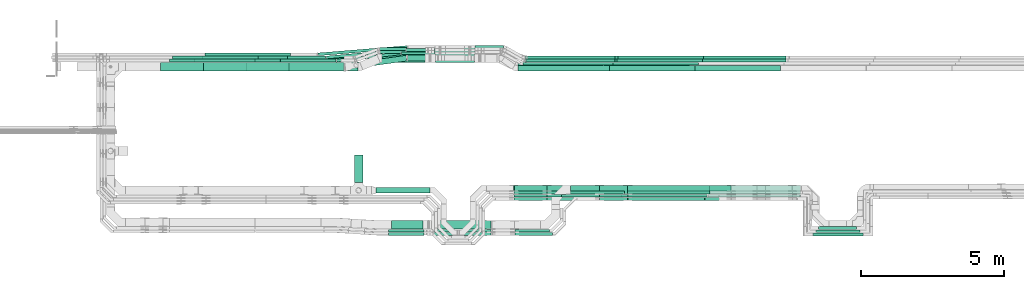
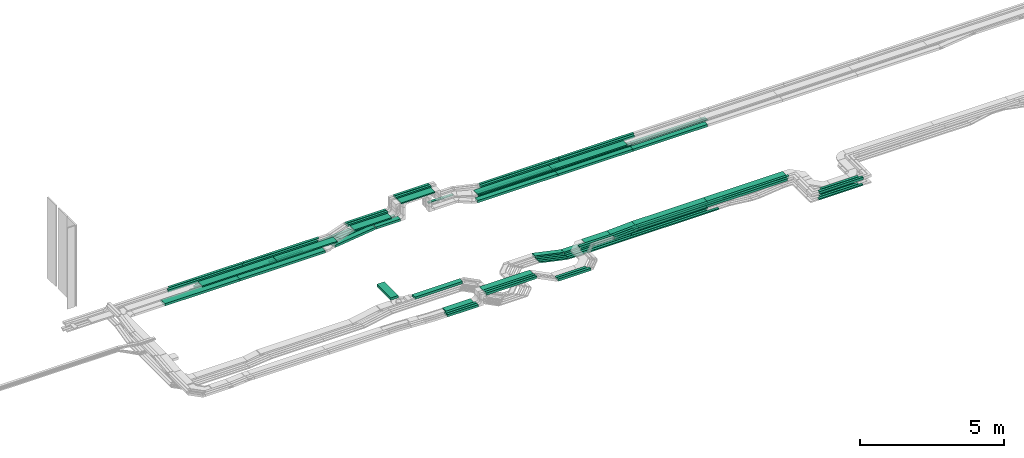
# One storey, part 2 of 32: 81 flow segments.
"""IFC2X3 building model written with IfcOpenShell, lengths in millimetres."""

from ifc_helpers import new_model, entity, si_unit, converted_unit, derived_unit, direction, frame, origin, origin_2d_with_axis, place, context, subcontext, project, spatial, rectangle, extrude, type_object, element, save


model = new_model("IFC2X3")

# Units and contexts
model_context = context("Model", 3, precision=0.01, world=origin(), true_north=direction((6.12303176911189e-17, 1.0)))
body_context = subcontext(model_context, "Body", "Model", "MODEL_VIEW")
ifc_project = project(units=[si_unit("LENGTHUNIT", "METRE", prefix="MILLI"), si_unit("AREAUNIT", "SQUARE_METRE"), si_unit("VOLUMEUNIT", "CUBIC_METRE"), converted_unit("PLANEANGLEUNIT", "DEGREE", entity("IfcRatioMeasure", 0.0174532925199433), si_unit("PLANEANGLEUNIT", "RADIAN"), dimensions=[0, 0, 0, 0, 0, 0, 0]), si_unit("MASSUNIT", "GRAM", prefix="KILO"), derived_unit("MASSDENSITYUNIT", [(si_unit("MASSUNIT", "GRAM", prefix="KILO"), 1), (si_unit("LENGTHUNIT", "METRE"), -3)]), derived_unit("MOMENTOFINERTIAUNIT", [(si_unit("LENGTHUNIT", "METRE"), 4)]), si_unit("TIMEUNIT", "SECOND"), si_unit("FREQUENCYUNIT", "HERTZ"), si_unit("THERMODYNAMICTEMPERATUREUNIT", "DEGREE_CELSIUS"), derived_unit("THERMALTRANSMITTANCEUNIT", [(si_unit("MASSUNIT", "GRAM", prefix="KILO"), 1), (si_unit("THERMODYNAMICTEMPERATUREUNIT", "KELVIN"), -1), (si_unit("TIMEUNIT", "SECOND"), -3)]), derived_unit("VOLUMETRICFLOWRATEUNIT", [(si_unit("LENGTHUNIT", "METRE"), 3), (si_unit("TIMEUNIT", "SECOND"), -1)]), derived_unit("MASSFLOWRATEUNIT", [(si_unit("MASSUNIT", "GRAM", prefix="KILO"), 1), (si_unit("TIMEUNIT", "SECOND"), -1)]), derived_unit("ROTATIONALFREQUENCYUNIT", [(si_unit("TIMEUNIT", "SECOND"), -1)]), si_unit("ELECTRICCURRENTUNIT", "AMPERE"), si_unit("ELECTRICVOLTAGEUNIT", "VOLT"), si_unit("POWERUNIT", "WATT"), si_unit("FORCEUNIT", "NEWTON", prefix="KILO"), si_unit("ILLUMINANCEUNIT", "LUX"), si_unit("LUMINOUSFLUXUNIT", "LUMEN"), si_unit("LUMINOUSINTENSITYUNIT", "CANDELA"), derived_unit("USERDEFINED", [(si_unit("MASSUNIT", "GRAM", prefix="KILO"), -1), (si_unit("LENGTHUNIT", "METRE"), -2), (si_unit("TIMEUNIT", "SECOND"), 3), (si_unit("LUMINOUSFLUXUNIT", "LUMEN"), 1)]), derived_unit("LINEARVELOCITYUNIT", [(si_unit("LENGTHUNIT", "METRE"), 1), (si_unit("TIMEUNIT", "SECOND"), -1)]), si_unit("PRESSUREUNIT", "PASCAL"), derived_unit("USERDEFINED", [(si_unit("LENGTHUNIT", "METRE"), -2), (si_unit("MASSUNIT", "GRAM", prefix="KILO"), 1), (si_unit("TIMEUNIT", "SECOND"), -2)]), derived_unit("LINEARFORCEUNIT", [(si_unit("MASSUNIT", "GRAM", prefix="KILO"), 1), (si_unit("LENGTHUNIT", "METRE"), 1), (si_unit("TIMEUNIT", "SECOND"), -2), (si_unit("LENGTHUNIT", "METRE"), -1)]), derived_unit("PLANARFORCEUNIT", [(si_unit("MASSUNIT", "GRAM", prefix="KILO"), 1), (si_unit("LENGTHUNIT", "METRE"), 1), (si_unit("TIMEUNIT", "SECOND"), -2), (si_unit("LENGTHUNIT", "METRE"), -2)])], contexts=[model_context])

# Site, building, storey
site_placement = place(None, origin())
site = spatial("IfcSite", under=ifc_project, at=site_placement, CompositionType="ELEMENT")
building_placement = place(site_placement, origin())
building = spatial("IfcBuilding", under=site, at=building_placement, CompositionType="ELEMENT")
storey_placement = place(building_placement, frame((0.0, 0.0, 8100.0)))
storey = spatial("IfcBuildingStorey", under=building, at=storey_placement, CompositionType="ELEMENT", Elevation=8100.0)

# Flow segments
cable_carrier_segment_type = type_object("IfcCableCarrierSegmentType", PredefinedType="CABLETRAYSEGMENT")
flow_segment_1_placement = place(storey_placement, frame((26941.01, 10275.0, 2800.0)))
element("IfcFlowSegment", 1, at=flow_segment_1_placement, inside=storey, type_object=cable_carrier_segment_type, context=body_context, shape_type="SweptSolid", body=[
    extrude(rectangle(XDim=962.025403932725, YDim=300.000000000001, at=origin_2d_with_axis()), frame((150.0, 481.01, 0.0), z_axis=(0.0, 0.0, 1.0), x_axis=(0.0, 1.0, 0.0)), (0.0, 0.0, 1.0), 99.9999999999968),
])
flow_segment_2_placement = place(storey_placement, frame((23148.44, 14174.5, 2565.0)))
element("IfcFlowSegment", 2, at=flow_segment_2_placement, inside=storey, type_object=cable_carrier_segment_type, context=body_context, shape_type="SweptSolid", body=[
    extrude(rectangle(XDim=3423.65642864429, YDim=300.000000000001, at=origin_2d_with_axis()), frame((1711.83, 150.0, 0.0), z_axis=(0.0, 0.0, 1.0), x_axis=(-1.0, 0.0, 0.0)), (0.0, 0.0, 1.0), 99.9999999999989),
])
flow_segment_3_placement = place(storey_placement, frame((28591.69, 14750.06, 2565.34)))
element("IfcFlowSegment", 3, at=flow_segment_3_placement, inside=storey, type_object=cable_carrier_segment_type, context=body_context, shape_type="SweptSolid", body=[
    extrude(rectangle(XDim=1171.51047122399, YDim=99.9999999999989, at=origin_2d_with_axis()), frame((585.76, 50.0, 0.0), z_axis=(0.0, 0.0, 1.0), x_axis=(-1.0, 0.0, 0.0)), (0.0, 0.0, 1.0), 50.0000000000016),
])
flow_segment_4_placement = place(storey_placement, frame((28756.97, 14860.06, 2570.0)))
element("IfcFlowSegment", 4, at=flow_segment_4_placement, inside=storey, type_object=cable_carrier_segment_type, context=body_context, shape_type="SweptSolid", body=[
    extrude(rectangle(XDim=1006.22734263624, YDim=99.9999999999989, at=origin_2d_with_axis()), frame((503.11, 50.0, 0.0), z_axis=(0.0, 0.0, 1.0), x_axis=(-1.0, 0.0, 0.0)), (0.0, 0.0, 1.0), 50.0000000000016),
])
flow_segment_5_placement = place(storey_placement, frame((27693.01, 9895.0, 2800.0)))
element("IfcFlowSegment", 5, at=flow_segment_5_placement, inside=storey, type_object=cable_carrier_segment_type, context=body_context, shape_type="SweptSolid", body=[
    extrude(rectangle(XDim=1902.46225527867, YDim=199.999999999998, at=origin_2d_with_axis()), frame((951.23, 100.0, 0.0)), (0.0, 0.0, 1.0), 100.000000000001),
])
flow_segment_6_placement = place(storey_placement, frame((39344.26, 9755.0, 2800.01)))
element("IfcFlowSegment", 6, at=flow_segment_6_placement, inside=storey, type_object=cable_carrier_segment_type, context=body_context, shape_type="SweptSolid", body=[
    extrude(rectangle(XDim=3242.93310217294, YDim=99.9999999999989, at=origin_2d_with_axis()), frame((1621.47, 50.0, 0.0), z_axis=(0.0, 0.0, 1.0), x_axis=(-1.0, 0.0, 0.0)), (0.0, 0.0, 1.0), 100.000000000001),
])
flow_segment_7_placement = place(storey_placement, frame((39398.1, 9875.0, 2800.02)))
element("IfcFlowSegment", 7, at=flow_segment_7_placement, inside=storey, type_object=cable_carrier_segment_type, context=body_context, shape_type="SweptSolid", body=[
    extrude(rectangle(XDim=3173.08952314652, YDim=300.000000000001, at=origin_2d_with_axis()), frame((1586.54, 150.0, 0.0), z_axis=(0.0, 0.0, 1.0), x_axis=(-1.0, 0.0, 0.0)), (0.0, 0.0, 1.0), 50.0000000000016),
])
flow_segment_8_placement = place(storey_placement, frame((31166.41, 14970.06, 2548.87)))
element("IfcFlowSegment", 8, at=flow_segment_8_placement, inside=storey, type_object=cable_carrier_segment_type, context=body_context, shape_type="SweptSolid", body=[
    extrude(rectangle(XDim=998.256803593107, YDim=99.9999999999989, at=origin_2d_with_axis()), frame((499.13, 50.0, 0.0)), (0.0, 0.0, 1.0), 50.0000000000016),
])
flow_segment_9_placement = place(storey_placement, frame((29758.2, 14900.06, 3325.0)))
element("IfcFlowSegment", 9, at=flow_segment_9_placement, inside=storey, type_object=cable_carrier_segment_type, context=body_context, shape_type="SweptSolid", body=[
    extrude(rectangle(XDim=1413.21398337131, YDim=99.9999999999989, at=origin_2d_with_axis()), frame((706.61, 50.0, 0.0)), (0.0, 0.0, 1.0), 99.9999999999989),
])
flow_segment_10_placement = place(storey_placement, frame((29758.2, 14790.06, 3325.0)))
element("IfcFlowSegment", 10, at=flow_segment_10_placement, inside=storey, type_object=cable_carrier_segment_type, context=body_context, shape_type="SweptSolid", body=[
    extrude(rectangle(XDim=1413.2139833713, YDim=99.9999999999989, at=origin_2d_with_axis()), frame((706.61, 50.0, 0.0)), (0.0, 0.0, 1.0), 99.9999999999989),
])
flow_segment_11_placement = place(storey_placement, frame((29783.2, 14480.06, 3325.0)))
element("IfcFlowSegment", 11, at=flow_segment_11_placement, inside=storey, type_object=cable_carrier_segment_type, context=body_context, shape_type="SweptSolid", body=[
    extrude(rectangle(XDim=1363.2139833713, YDim=300.000000000001, at=origin_2d_with_axis()), frame((681.61, 150.0, 0.0)), (0.0, 0.0, 1.0), 50.0000000000016),
])
flow_segment_12_placement = place(storey_placement, frame((43147.19, 8512.69, 2800.01)))
element("IfcFlowSegment", 12, at=flow_segment_12_placement, inside=storey, type_object=cable_carrier_segment_type, context=body_context, shape_type="SweptSolid", body=[
    extrude(rectangle(XDim=1512.20104272159, YDim=100.000000000001, at=origin_2d_with_axis()), frame((756.1, 50.0, 0.0)), (0.0, 0.0, 1.0), 99.9999999999989),
])
flow_segment_13_placement = place(storey_placement, frame((43027.19, 8402.69, 2799.28)))
element("IfcFlowSegment", 13, at=flow_segment_13_placement, inside=storey, type_object=cable_carrier_segment_type, context=body_context, shape_type="SweptSolid", body=[
    extrude(rectangle(XDim=1757.70736084199, YDim=100.000000000001, at=origin_2d_with_axis()), frame((878.85, 50.0, 0.0)), (0.0, 0.0, 1.0), 99.9999999999989),
])
flow_segment_14_placement = place(storey_placement, frame((43217.19, 8622.69, 2544.93)))
element("IfcFlowSegment", 14, at=flow_segment_14_placement, inside=storey, type_object=cable_carrier_segment_type, context=body_context, shape_type="SweptSolid", body=[
    extrude(rectangle(XDim=1332.2010427216, YDim=99.9999999999989, at=origin_2d_with_axis()), frame((666.1, 50.0, 0.0)), (0.0, 0.0, 1.0), 50.0000000000016),
])
flow_segment_15_placement = place(storey_placement, frame((43107.19, 8512.69, 2546.32)))
element("IfcFlowSegment", 15, at=flow_segment_15_placement, inside=storey, type_object=cable_carrier_segment_type, context=body_context, shape_type="SweptSolid", body=[
    extrude(rectangle(XDim=1552.2010427216, YDim=99.9999999999989, at=origin_2d_with_axis()), frame((776.1, 50.0, 0.0)), (0.0, 0.0, 1.0), 50.0000000000016),
])
flow_segment_16_placement = place(storey_placement, frame((42997.19, 8402.69, 2546.67)))
element("IfcFlowSegment", 16, at=flow_segment_16_placement, inside=storey, type_object=cable_carrier_segment_type, context=body_context, shape_type="SweptSolid", body=[
    extrude(rectangle(XDim=1772.70736117974, YDim=100.000000000001, at=origin_2d_with_axis()), frame((886.35, 50.0, 0.0)), (0.0, 0.0, 1.0), 50.0000000000016),
])
flow_segment_17_placement = place(storey_placement, frame((32683.5, 14182.28, 2854.5)))
element("IfcFlowSegment", 17, at=flow_segment_17_placement, inside=storey, type_object=cable_carrier_segment_type, context=body_context, shape_type="SweptSolid", body=[
    extrude(rectangle(XDim=2998.73000000508, YDim=300.000000000001, at=origin_2d_with_axis()), frame((1499.37, 150.0, 0.0)), (0.0, 0.0, 1.0), 50.0000000000016),
])
flow_segment_18_placement = place(storey_placement, frame((32966.27, 14492.28, 2855.0)))
element("IfcFlowSegment", 18, at=flow_segment_18_placement, inside=storey, type_object=cable_carrier_segment_type, context=body_context, shape_type="SweptSolid", body=[
    extrude(rectangle(XDim=3170.75891996771, YDim=99.9999999999989, at=origin_2d_with_axis()), frame((1585.38, 50.0, 0.0)), (0.0, 0.0, 1.0), 99.9999999999989),
])
flow_segment_19_placement = place(storey_placement, frame((33011.91, 14602.28, 2855.0)))
element("IfcFlowSegment", 19, at=flow_segment_19_placement, inside=storey, type_object=cable_carrier_segment_type, context=body_context, shape_type="SweptSolid", body=[
    extrude(rectangle(XDim=3172.25095291534, YDim=99.9999999999989, at=origin_2d_with_axis()), frame((1586.13, 50.0, 0.0)), (0.0, 0.0, 1.0), 99.9999999999989),
])
flow_segment_20_placement = place(storey_placement, frame((27909.76, 14480.06, 2840.02)))
element("IfcFlowSegment", 20, at=flow_segment_20_placement, inside=storey, type_object=cable_carrier_segment_type, context=body_context, shape_type="SweptSolid", body=[
    extrude(rectangle(XDim=1503.44239818237, YDim=300.000000000001, at=origin_2d_with_axis()), frame((751.72, 150.0, 0.0), z_axis=(0.0, 0.0, 1.0), x_axis=(-1.0, 0.0, 0.0)), (0.0, 0.0, 1.0), 50.0000000000016),
])
flow_segment_21_placement = place(storey_placement, frame((27841.26, 14790.06, 2840.0)))
element("IfcFlowSegment", 21, at=flow_segment_21_placement, inside=storey, type_object=cable_carrier_segment_type, context=body_context, shape_type="SweptSolid", body=[
    extrude(rectangle(XDim=1596.94010719343, YDim=99.9999999999989, at=origin_2d_with_axis()), frame((798.47, 50.0, 0.0), z_axis=(0.0, 0.0, 1.0), x_axis=(-1.0, 0.0, 0.0)), (0.0, 0.0, 1.0), 99.9999999999989),
])
flow_segment_22_placement = place(storey_placement, frame((27825.51, 14900.06, 2840.0)))
element("IfcFlowSegment", 22, at=flow_segment_22_placement, inside=storey, type_object=cable_carrier_segment_type, context=body_context, shape_type="SweptSolid", body=[
    extrude(rectangle(XDim=1612.69321013494, YDim=99.9999999999989, at=origin_2d_with_axis()), frame((806.35, 50.0, 0.0), z_axis=(0.0, 0.0, 1.0), x_axis=(-1.0, 0.0, 0.0)), (0.0, 0.0, 1.0), 99.9999999999989),
])
flow_segment_23_placement = place(storey_placement, frame((32920.1, 14602.28, 2548.87)))
element("IfcFlowSegment", 23, at=flow_segment_23_placement, inside=storey, type_object=cable_carrier_segment_type, context=body_context, shape_type="SweptSolid", body=[
    extrude(rectangle(XDim=3151.80224385144, YDim=99.9999999999989, at=origin_2d_with_axis()), frame((1575.9, 50.0, 0.0)), (0.0, 0.0, 1.0), 50.0000000000016),
])
for number, where in (
    (24, (32914.63, 14492.28, 2548.35)),
    (25, (32852.18, 14382.28, 2548.88)),
):
    element("IfcFlowSegment", number, at=place(storey_placement, frame(where)), inside=storey, type_object=cable_carrier_segment_type, context=body_context, shape_type="SweptSolid", body=[
        extrude(rectangle(XDim=3151.80224385145, YDim=99.9999999999989, at=origin_2d_with_axis()), frame((1575.9, 50.0, 0.0)), (0.0, 0.0, 1.0), 50.0000000000016),
    ])
flow_segment_24_placement = place(storey_placement, frame((28805.18, 14532.28, 2565.0)))
element("IfcFlowSegment", 26, at=flow_segment_24_placement, inside=storey, type_object=cable_carrier_segment_type, context=body_context, shape_type="SweptSolid", body=[
    extrude(rectangle(XDim=983.02375307789, YDim=199.999999999998, at=origin_2d_with_axis()), frame((491.51, 100.0, 0.0), z_axis=(0.0, 0.0, 1.0), x_axis=(-1.0, 0.0, 0.0)), (0.0, 0.0, 1.0), 99.9999999999989),
])
flow_segment_25_placement = place(storey_placement, frame((26317.41, 14493.99, 2565.34)))
element("IfcFlowSegment", 27, at=flow_segment_25_placement, inside=storey, type_object=cable_carrier_segment_type, context=body_context, shape_type="SweptSolid", body=[
    extrude(rectangle(XDim=2258.501959598, YDim=99.9999999999987, at=origin_2d_with_axis()), frame((1127.68, 177.18, 0.0), z_axis=(0.0, 0.0, 1.0), x_axis=(-0.993605819509294, -0.112904718401246, 0.0)), (0.0, 0.0, 1.0), 50.0000000000016),
])
flow_segment_26_placement = place(storey_placement, frame((25948.97, 14603.42, 2570.0)))
element("IfcFlowSegment", 28, at=flow_segment_26_placement, inside=storey, type_object=cable_carrier_segment_type, context=body_context, shape_type="SweptSolid", body=[
    extrude(rectangle(XDim=2794.85823056188, YDim=100.000000000001, at=origin_2d_with_axis()), frame((1396.14, 177.75, 0.0), z_axis=(0.0, 0.0, 1.0), x_axis=(-0.995798961229457, -0.0915665267132783, 0.0)), (0.0, 0.0, 1.0), 50.0000000000016),
])
flow_segment_27_placement = place(storey_placement, frame((25661.84, 14713.2, 2570.0)))
element("IfcFlowSegment", 29, at=flow_segment_27_placement, inside=storey, type_object=cable_carrier_segment_type, context=body_context, shape_type="SweptSolid", body=[
    extrude(rectangle(XDim=3133.42412206089, YDim=100.000000000001, at=origin_2d_with_axis()), frame((1565.55, 177.97, 0.0), z_axis=(0.0, 0.0, 1.0), x_axis=(-0.996649779456723, -0.0817876342050842, 0.0)), (0.0, 0.0, 1.0), 50.0000000000016),
])
flow_segment_28_placement = place(storey_placement, frame((26998.0, 14284.12, 2565.0)))
element("IfcFlowSegment", 30, at=flow_segment_28_placement, inside=storey, type_object=cable_carrier_segment_type, context=body_context, shape_type="SweptSolid", body=[
    extrude(rectangle(XDim=1773.75184296437, YDim=200.000000000002, at=origin_2d_with_axis()), frame((892.17, 222.31, 0.0), z_axis=(-7.09771272186529e-08, -9.962867704376e-09, 1.0), x_axis=(0.990291738549351, 0.139004577481819, 7.16729469263524e-08)), (0.0, 0.0, 1.0), 99.9999999999991),
])
flow_segment_29_placement = place(storey_placement, frame((29699.46, 8532.45, 3165.02)))
element("IfcFlowSegment", 31, at=flow_segment_29_placement, inside=storey, type_object=cable_carrier_segment_type, context=body_context, shape_type="SweptSolid", body=[
    extrude(rectangle(XDim=2026.05061924203, YDim=99.9999999999989, at=origin_2d_with_axis()), frame((1013.03, 50.0, 0.0)), (0.0, 0.0, 1.0), 99.9999999999989),
])
flow_segment_30_placement = place(storey_placement, frame((29699.46, 8422.45, 3164.3)))
element("IfcFlowSegment", 32, at=flow_segment_30_placement, inside=storey, type_object=cable_carrier_segment_type, context=body_context, shape_type="SweptSolid", body=[
    extrude(rectangle(XDim=2026.05032171429, YDim=99.9999999999989, at=origin_2d_with_axis()), frame((1013.03, 50.0, 0.0)), (0.0, 0.0, 1.0), 99.9999999999989),
])
flow_segment_31_placement = place(storey_placement, frame((29724.46, 8642.05, 3165.02)))
element("IfcFlowSegment", 33, at=flow_segment_31_placement, inside=storey, type_object=cable_carrier_segment_type, context=body_context, shape_type="SweptSolid", body=[
    extrude(rectangle(XDim=2007.04579485695, YDim=300.000000000001, at=origin_2d_with_axis()), frame((1003.52, 150.0, 0.0)), (0.0, 0.0, 1.0), 50.0000000000016),
])
flow_segment_32_placement = place(storey_placement, frame((32672.45, 14174.5, 2548.88)))
element("IfcFlowSegment", 34, at=flow_segment_32_placement, inside=storey, type_object=cable_carrier_segment_type, context=body_context, shape_type="SweptSolid", body=[
    extrude(rectangle(XDim=3209.55577942012, YDim=200.000000000002, at=origin_2d_with_axis()), frame((1604.78, 100.0, 0.0)), (0.0, 0.0, 1.0), 99.9999999999989),
])
flow_segment_33_placement = place(storey_placement, frame((39224.26, 9645.0, 2799.28)))
element("IfcFlowSegment", 35, at=flow_segment_33_placement, inside=storey, type_object=cable_carrier_segment_type, context=body_context, shape_type="SweptSolid", body=[
    extrude(rectangle(XDim=3242.93310217294, YDim=100.000000000001, at=origin_2d_with_axis()), frame((1621.47, 50.0, 0.0), z_axis=(0.0, 0.0, 1.0), x_axis=(-1.0, 0.0, 0.0)), (0.0, 0.0, 1.0), 99.9999999999989),
])
flow_segment_34_placement = place(storey_placement, frame((21649.82, 14182.28, 2840.02)))
element("IfcFlowSegment", 36, at=flow_segment_34_placement, inside=storey, type_object=cable_carrier_segment_type, context=body_context, shape_type="SweptSolid", body=[
    extrude(rectangle(XDim=2997.46000001016, YDim=300.000000000001, at=origin_2d_with_axis()), frame((1498.73, 150.0, 0.0)), (0.0, 0.0, 1.0), 50.0000000000016),
])
flow_segment_35_placement = place(storey_placement, frame((24649.82, 14182.28, 2840.02)))
element("IfcFlowSegment", 37, at=flow_segment_35_placement, inside=storey, type_object=cable_carrier_segment_type, context=body_context, shape_type="SweptSolid", body=[
    extrude(rectangle(XDim=2417.52833008933, YDim=300.000000000001, at=origin_2d_with_axis()), frame((1208.76, 150.0, 0.0)), (0.0, 0.0, 1.0), 50.0000000000016),
])
flow_segment_36_placement = place(storey_placement, frame((36074.45, 14602.28, 2548.87)))
element("IfcFlowSegment", 38, at=flow_segment_36_placement, inside=storey, type_object=cable_carrier_segment_type, context=body_context, shape_type="SweptSolid", body=[
    extrude(rectangle(XDim=2997.46000001016, YDim=99.9999999999989, at=origin_2d_with_axis()), frame((1498.73, 50.0, 0.0)), (0.0, 0.0, 1.0), 50.0000000000016),
])
flow_segment_37_placement = place(storey_placement, frame((39074.45, 14602.28, 2548.87)))
element("IfcFlowSegment", 39, at=flow_segment_37_placement, inside=storey, type_object=cable_carrier_segment_type, context=body_context, shape_type="SweptSolid", body=[
    extrude(rectangle(XDim=2997.46000001017, YDim=99.9999999999989, at=origin_2d_with_axis()), frame((1498.73, 50.0, 0.0)), (0.0, 0.0, 1.0), 50.0000000000016),
])
for number, where in (
    (40, (21709.61, 14712.28, 2570.0)),
    (41, (21594.05, 14602.28, 2570.0)),
):
    element("IfcFlowSegment", number, at=place(storey_placement, frame(where)), inside=storey, type_object=cable_carrier_segment_type, context=body_context, shape_type="SweptSolid", body=[
        extrude(rectangle(XDim=2997.46000001016, YDim=99.9999999999989, at=origin_2d_with_axis()), frame((1498.73, 50.0, 0.0)), (0.0, 0.0, 1.0), 50.0000000000016),
    ])
flow_segment_38_placement = place(storey_placement, frame((24594.05, 14602.28, 2570.0)))
element("IfcFlowSegment", 42, at=flow_segment_38_placement, inside=storey, type_object=cable_carrier_segment_type, context=body_context, shape_type="SweptSolid", body=[
    extrude(rectangle(XDim=1339.19101644203, YDim=99.9999999999989, at=origin_2d_with_axis()), frame((669.6, 50.0, 0.0)), (0.0, 0.0, 1.0), 50.0000000000016),
])
flow_segment_39_placement = place(storey_placement, frame((36304.26, 9755.0, 2546.32)))
element("IfcFlowSegment", 43, at=flow_segment_39_placement, inside=storey, type_object=cable_carrier_segment_type, context=body_context, shape_type="SweptSolid", body=[
    extrude(rectangle(XDim=2997.46000001017, YDim=99.9999999999989, at=origin_2d_with_axis()), frame((1498.73, 50.0, 0.0)), (0.0, 0.0, 1.0), 50.0000000000016),
])
flow_segment_40_placement = place(storey_placement, frame((33696.84, 9755.0, 2546.32)))
element("IfcFlowSegment", 44, at=flow_segment_40_placement, inside=storey, type_object=cable_carrier_segment_type, context=body_context, shape_type="SweptSolid", body=[
    extrude(rectangle(XDim=2604.87236655356, YDim=99.9999999999989, at=origin_2d_with_axis()), frame((1302.44, 50.0, 0.0), z_axis=(0.0, 0.0, 1.0), x_axis=(-1.0, 0.0, 0.0)), (0.0, 0.0, 1.0), 50.0000000000016),
])
flow_segment_41_placement = place(storey_placement, frame((36068.97, 14492.28, 2548.35)))
element("IfcFlowSegment", 45, at=flow_segment_41_placement, inside=storey, type_object=cable_carrier_segment_type, context=body_context, shape_type="SweptSolid", body=[
    extrude(rectangle(XDim=2997.46000001016, YDim=99.9999999999989, at=origin_2d_with_axis()), frame((1498.73, 50.0, 0.0)), (0.0, 0.0, 1.0), 50.0000000000016),
])
flow_segment_42_placement = place(storey_placement, frame((39068.97, 14492.28, 2548.35)))
element("IfcFlowSegment", 46, at=flow_segment_42_placement, inside=storey, type_object=cable_carrier_segment_type, context=body_context, shape_type="SweptSolid", body=[
    extrude(rectangle(XDim=2997.46000001017, YDim=99.9999999999989, at=origin_2d_with_axis()), frame((1498.73, 50.0, 0.0)), (0.0, 0.0, 1.0), 50.0000000000016),
])
for number, where in (
    (47, (20464.1, 14492.28, 2840.0)),
    (48, (23464.1, 14492.28, 2840.0)),
    (49, (36139.57, 14492.28, 2855.0)),
):
    element("IfcFlowSegment", number, at=place(storey_placement, frame(where)), inside=storey, type_object=cable_carrier_segment_type, context=body_context, shape_type="SweptSolid", body=[
        extrude(rectangle(XDim=2997.46000001016, YDim=99.9999999999989, at=origin_2d_with_axis()), frame((1498.73, 50.0, 0.0)), (0.0, 0.0, 1.0), 99.9999999999989),
    ])
flow_segment_43_placement = place(storey_placement, frame((20148.44, 14174.5, 2565.0)))
element("IfcFlowSegment", 50, at=flow_segment_43_placement, inside=storey, type_object=cable_carrier_segment_type, context=body_context, shape_type="SweptSolid", body=[
    extrude(rectangle(XDim=2997.46000001016, YDim=300.000000000001, at=origin_2d_with_axis()), frame((1498.73, 150.0, 0.0), z_axis=(0.0, 0.0, 1.0), x_axis=(-1.0, 0.0, 0.0)), (0.0, 0.0, 1.0), 99.9999999999989),
])
for number, where in (
    (51, (35884.54, 14174.5, 2548.88)),
    (52, (38884.54, 14174.5, 2548.88)),
):
    element("IfcFlowSegment", number, at=place(storey_placement, frame(where)), inside=storey, type_object=cable_carrier_segment_type, context=body_context, shape_type="SweptSolid", body=[
        extrude(rectangle(XDim=2997.46000001016, YDim=199.999999999998, at=origin_2d_with_axis()), frame((1498.73, 100.0, 0.0)), (0.0, 0.0, 1.0), 99.9999999999989),
    ])
flow_segment_44_placement = place(storey_placement, frame((35684.77, 14182.28, 2854.5)))
element("IfcFlowSegment", 53, at=flow_segment_44_placement, inside=storey, type_object=cable_carrier_segment_type, context=body_context, shape_type="SweptSolid", body=[
    extrude(rectangle(XDim=2997.46000001016, YDim=300.000000000001, at=origin_2d_with_axis()), frame((1498.73, 150.0, 0.0)), (0.0, 0.0, 1.0), 50.0000000000016),
])
flow_segment_45_placement = place(storey_placement, frame((36493.24, 9975.0, 2546.76)))
element("IfcFlowSegment", 54, at=flow_segment_45_placement, inside=storey, type_object=cable_carrier_segment_type, context=body_context, shape_type="SweptSolid", body=[
    extrude(rectangle(XDim=3655.89665624518, YDim=199.999999950251, at=origin_2d_with_axis()), frame((1827.95, 100.0, 0.32), z_axis=(0.000172427610674945, 0.0, 0.99999998513436), x_axis=(0.99999998513436, 0.0, -0.000172427610674945)), (0.0, 0.0, 1.0), 99.999999975123),
])
flow_segment_46_placement = place(storey_placement, frame((33699.52, 9975.0, 2547.39)))
element("IfcFlowSegment", 55, at=flow_segment_46_placement, inside=storey, type_object=cable_carrier_segment_type, context=body_context, shape_type="SweptSolid", body=[
    extrude(rectangle(XDim=2791.19312349986, YDim=200.000000000002, at=origin_2d_with_axis()), frame((1395.6, 100.0, 0.0), z_axis=(0.0, 0.0, 1.0), x_axis=(-1.0, 0.0, 0.0)), (0.0, 0.0, 1.0), 99.9999999999989),
])
flow_segment_47_placement = place(storey_placement, frame((21344.78, 14492.28, 2565.34)))
element("IfcFlowSegment", 56, at=flow_segment_47_placement, inside=storey, type_object=cable_carrier_segment_type, context=body_context, shape_type="SweptSolid", body=[
    extrude(rectangle(XDim=2997.46000001016, YDim=99.9999999999989, at=origin_2d_with_axis()), frame((1498.73, 50.0, 0.0)), (0.0, 0.0, 1.0), 50.0000000000016),
])
flow_segment_48_placement = place(storey_placement, frame((24344.78, 14492.28, 2565.34)))
element("IfcFlowSegment", 57, at=flow_segment_48_placement, inside=storey, type_object=cable_carrier_segment_type, context=body_context, shape_type="SweptSolid", body=[
    extrude(rectangle(XDim=1953.69647406687, YDim=99.9999999999989, at=origin_2d_with_axis()), frame((976.85, 50.0, 0.0)), (0.0, 0.0, 1.0), 50.0000000000016),
])
flow_segment_49_placement = place(storey_placement, frame((36414.26, 9865.0, 2544.93)))
element("IfcFlowSegment", 58, at=flow_segment_49_placement, inside=storey, type_object=cable_carrier_segment_type, context=body_context, shape_type="SweptSolid", body=[
    extrude(rectangle(XDim=2997.46000001016, YDim=99.9999999999989, at=origin_2d_with_axis()), frame((1498.73, 50.0, 0.0), z_axis=(0.0, 0.0, 1.0), x_axis=(-1.0, 0.0, 0.0)), (0.0, 0.0, 1.0), 50.0000000000016),
])
flow_segment_50_placement = place(storey_placement, frame((33696.86, 9865.0, 2544.93)))
element("IfcFlowSegment", 59, at=flow_segment_50_placement, inside=storey, type_object=cable_carrier_segment_type, context=body_context, shape_type="SweptSolid", body=[
    extrude(rectangle(XDim=2714.85558325048, YDim=99.9999999999989, at=origin_2d_with_axis()), frame((1357.43, 50.0, 0.0), z_axis=(0.0, 0.0, 1.0), x_axis=(-1.0, 0.0, 0.0)), (0.0, 0.0, 1.0), 50.0000000000016),
])
flow_segment_51_placement = place(storey_placement, frame((33696.84, 9645.0, 2546.63)))
element("IfcFlowSegment", 60, at=flow_segment_51_placement, inside=storey, type_object=cable_carrier_segment_type, context=body_context, shape_type="SweptSolid", body=[
    extrude(rectangle(XDim=6031.01020597482, YDim=100.000000000001, at=origin_2d_with_axis()), frame((3015.51, 50.0, 0.0), z_axis=(0.0, 0.0, 1.0), x_axis=(-1.0, 0.0, 0.0)), (0.0, 0.0, 1.0), 50.0000000000016),
])
for number, where in (
    (61, (20574.1, 14602.28, 2840.0)),
    (62, (23574.1, 14602.28, 2840.0)),
    (63, (36186.7, 14602.28, 2855.0)),
):
    element("IfcFlowSegment", number, at=place(storey_placement, frame(where)), inside=storey, type_object=cable_carrier_segment_type, context=body_context, shape_type="SweptSolid", body=[
        extrude(rectangle(XDim=2997.46000001016, YDim=99.9999999999989, at=origin_2d_with_axis()), frame((1498.73, 50.0, 0.0)), (0.0, 0.0, 1.0), 99.9999999999989),
    ])
flow_segment_52_placement = place(storey_placement, frame((36006.52, 14382.28, 2548.88)))
element("IfcFlowSegment", 64, at=flow_segment_52_placement, inside=storey, type_object=cable_carrier_segment_type, context=body_context, shape_type="SweptSolid", body=[
    extrude(rectangle(XDim=2997.46000001016, YDim=99.9999999999989, at=origin_2d_with_axis()), frame((1498.73, 50.0, 0.0)), (0.0, 0.0, 1.0), 50.0000000000016),
])
flow_segment_53_placement = place(storey_placement, frame((36523.45, 9875.0, 2800.02)))
element("IfcFlowSegment", 65, at=flow_segment_53_placement, inside=storey, type_object=cable_carrier_segment_type, context=body_context, shape_type="SweptSolid", body=[
    extrude(rectangle(XDim=2872.11009264089, YDim=300.000000000001, at=origin_2d_with_axis()), frame((1436.06, 150.0, 0.0), z_axis=(0.0, 0.0, 1.0), x_axis=(-1.0, 0.0, 0.0)), (0.0, 0.0, 1.0), 50.0000000000016),
])
flow_segment_54_placement = place(storey_placement, frame((36524.08, 9755.0, 2800.01)))
element("IfcFlowSegment", 66, at=flow_segment_54_placement, inside=storey, type_object=cable_carrier_segment_type, context=body_context, shape_type="SweptSolid", body=[
    extrude(rectangle(XDim=2817.63419776496, YDim=99.9999999999989, at=origin_2d_with_axis()), frame((1408.82, 50.0, 0.0), z_axis=(0.0, 0.0, 1.0), x_axis=(-1.0, 0.0, 0.0)), (0.0, 0.0, 1.0), 99.9999999999968),
])
flow_segment_55_placement = place(storey_placement, frame((36524.08, 9645.0, 2799.28)))
element("IfcFlowSegment", 67, at=flow_segment_55_placement, inside=storey, type_object=cable_carrier_segment_type, context=body_context, shape_type="SweptSolid", body=[
    extrude(rectangle(XDim=2697.63419776494, YDim=99.9999999999989, at=origin_2d_with_axis()), frame((1348.82, 50.0, 0.0), z_axis=(0.0, 0.0, 1.0), x_axis=(-1.0, 0.0, 0.0)), (0.0, 0.0, 1.0), 99.9999999999989),
])
flow_segment_56_placement = place(storey_placement, frame((28145.46, 8532.45, 2789.67)))
element("IfcFlowSegment", 68, at=flow_segment_56_placement, inside=storey, type_object=cable_carrier_segment_type, context=body_context, shape_type="SweptSolid", body=[
    extrude(rectangle(XDim=1234.00000000056, YDim=100.000000000001, at=origin_2d_with_axis()), frame((617.0, 50.0, 0.0), z_axis=(0.0, 0.0, 1.0), x_axis=(-1.0, 0.0, 0.0)), (0.0, 0.0, 1.0), 99.9999999999989),
])
flow_segment_57_placement = place(storey_placement, frame((28245.46, 8642.05, 2790.02)))
element("IfcFlowSegment", 69, at=flow_segment_57_placement, inside=storey, type_object=cable_carrier_segment_type, context=body_context, shape_type="SweptSolid", body=[
    extrude(rectangle(XDim=1109.00000002828, YDim=299.999999999999, at=origin_2d_with_axis()), frame((554.5, 150.0, 0.0), z_axis=(0.0, 0.0, 1.0), x_axis=(-1.0, 0.0, 0.0)), (0.0, 0.0, 1.0), 50.0000000000016),
])
flow_segment_58_placement = place(storey_placement, frame((28145.46, 8422.45, 2789.32)))
element("IfcFlowSegment", 70, at=flow_segment_58_placement, inside=storey, type_object=cable_carrier_segment_type, context=body_context, shape_type="SweptSolid", body=[
    extrude(rectangle(XDim=1234.00000000042, YDim=100.000000000001, at=origin_2d_with_axis()), frame((617.0, 50.0, 0.0), z_axis=(0.0, 0.0, 1.0), x_axis=(-1.0, 0.0, 0.0)), (0.0, 0.0, 1.0), 100.000000000001),
])
flow_segment_59_placement = place(storey_placement, frame((34520.32, 9875.0, 2750.02)))
element("IfcFlowSegment", 71, at=flow_segment_59_placement, inside=storey, type_object=cable_carrier_segment_type, context=body_context, shape_type="SweptSolid", body=[
    extrude(rectangle(XDim=1011.86137418036, YDim=300.000000000001, at=origin_2d_with_axis()), frame((505.93, 150.0, 0.0)), (0.0, 0.0, 1.0), 50.0000000000016),
])
flow_segment_60_placement = place(storey_placement, frame((34203.92, 9755.0, 2750.01)))
element("IfcFlowSegment", 72, at=flow_segment_60_placement, inside=storey, type_object=cable_carrier_segment_type, context=body_context, shape_type="SweptSolid", body=[
    extrude(rectangle(XDim=1327.63419776575, YDim=99.9999999999989, at=origin_2d_with_axis()), frame((663.82, 50.0, 0.0)), (0.0, 0.0, 1.0), 99.9999999999989),
])
flow_segment_61_placement = place(storey_placement, frame((32568.95, 8532.45, 2750.01)))
element("IfcFlowSegment", 73, at=flow_segment_61_placement, inside=storey, type_object=cable_carrier_segment_type, context=body_context, shape_type="SweptSolid", body=[
    extrude(rectangle(XDim=1208.96265936677, YDim=99.9999999999989, at=origin_2d_with_axis()), frame((604.48, 50.0, 0.0)), (0.0, 0.0, 1.0), 99.9999999999989),
])
flow_segment_62_placement = place(storey_placement, frame((32568.96, 8422.45, 2749.28)))
element("IfcFlowSegment", 74, at=flow_segment_62_placement, inside=storey, type_object=cable_carrier_segment_type, context=body_context, shape_type="SweptSolid", body=[
    extrude(rectangle(XDim=1318.96236183914, YDim=99.9999999999989, at=origin_2d_with_axis()), frame((659.48, 50.0, 0.0)), (0.0, 0.0, 1.0), 99.9999999999989),
])
flow_segment_63_placement = place(storey_placement, frame((35533.75, 9645.0, 2749.46)))
element("IfcFlowSegment", 75, at=flow_segment_63_placement, inside=storey, type_object=cable_carrier_segment_type, context=body_context, shape_type="SweptSolid", body=[
    extrude(rectangle(XDim=99.999999999999, YDim=99.9999999999989, at=origin_2d_with_axis()), frame((2.53, 50.0, 49.94), z_axis=(0.998721383285712, 0.0, 0.050552928380791), x_axis=(-0.050552928380791, 0.0, 0.998721383285712)), (0.0, 0.0, 1.0), 984.330782250709),
])
flow_segment_64_placement = place(storey_placement, frame((35533.75, 9755.0, 2750.19)))
element("IfcFlowSegment", 76, at=flow_segment_64_placement, inside=storey, type_object=cable_carrier_segment_type, context=body_context, shape_type="SweptSolid", body=[
    extrude(rectangle(XDim=99.999999999999, YDim=99.9999999999989, at=origin_2d_with_axis()), frame((2.53, 50.0, 49.94), z_axis=(0.998721383285712, 0.0, 0.050552928380791), x_axis=(-0.050552928380791, 0.0, 0.998721383285712)), (0.0, 0.0, 1.0), 984.330782250623),
])
flow_segment_65_placement = place(storey_placement, frame((35534.39, 9875.0, 2750.14)))
element("IfcFlowSegment", 77, at=flow_segment_65_placement, inside=storey, type_object=cable_carrier_segment_type, context=body_context, shape_type="SweptSolid", body=[
    extrude(rectangle(XDim=50.0000000000017, YDim=300.000000000001, at=origin_2d_with_axis()), frame((1.26, 150.0, 24.97), z_axis=(0.998721383285712, 0.0, 0.0505529283807888), x_axis=(-0.0505529283807888, 0.0, 0.998721383285712)), (0.0, 0.0, 1.0), 985.595413949781),
])
flow_segment_66_placement = place(storey_placement, frame((32529.01, 9645.0, 2548.08)))
element("IfcFlowSegment", 78, at=flow_segment_66_placement, inside=storey, type_object=cable_carrier_segment_type, context=body_context, shape_type="SweptSolid", body=[
    extrude(rectangle(XDim=49.9999999999996, YDim=100.000000000001, at=origin_2d_with_axis()), frame((5.32, 50.0, 276.04), z_axis=(0.977059422663216, 0.0, -0.212966862645394), x_axis=(0.212966862645394, 0.0, 0.977059422663216)), (0.0, 0.0, 1.0), 1181.45340824707),
])
flow_segment_67_placement = place(storey_placement, frame((32529.01, 9755.0, 2547.77)))
element("IfcFlowSegment", 79, at=flow_segment_67_placement, inside=storey, type_object=cable_carrier_segment_type, context=body_context, shape_type="SweptSolid", body=[
    extrude(rectangle(XDim=50.000000000001, YDim=99.9999999999989, at=origin_2d_with_axis()), frame((5.33, 50.0, 276.35), z_axis=(0.977004473697588, 0.0, -0.213218803989935), x_axis=(0.213218803989935, 0.0, 0.977004473697588)), (0.0, 0.0, 1.0), 1181.51275482673),
])
flow_segment_68_placement = place(storey_placement, frame((32529.0, 9865.0, 2546.39)))
element("IfcFlowSegment", 80, at=flow_segment_68_placement, inside=storey, type_object=cable_carrier_segment_type, context=body_context, shape_type="SweptSolid", body=[
    extrude(rectangle(XDim=49.9999999999984, YDim=99.9999999999989, at=origin_2d_with_axis()), frame((5.36, 50.0, 277.72), z_axis=(0.976759892794414, 0.0, -0.214336445403586), x_axis=(0.214336445403586, 0.0, 0.976759892794414)), (0.0, 0.0, 1.0), 1181.77710640849),
])
flow_segment_69_placement = place(storey_placement, frame((32526.33, 9975.0, 2549.98)))
element("IfcFlowSegment", 81, at=flow_segment_69_placement, inside=storey, type_object=cable_carrier_segment_type, context=body_context, shape_type="SweptSolid", body=[
    extrude(rectangle(XDim=99.9999999999999, YDim=200.000000000002, at=origin_2d_with_axis()), frame((10.62, 100.0, 298.58), z_axis=(0.977192506439557, 0.0, -0.212355375157721), x_axis=(0.212355375157721, 0.0, 0.977192506439557)), (0.0, 0.0, 1.0), 1175.93961725075),
])

save(model, "model.ifc")
